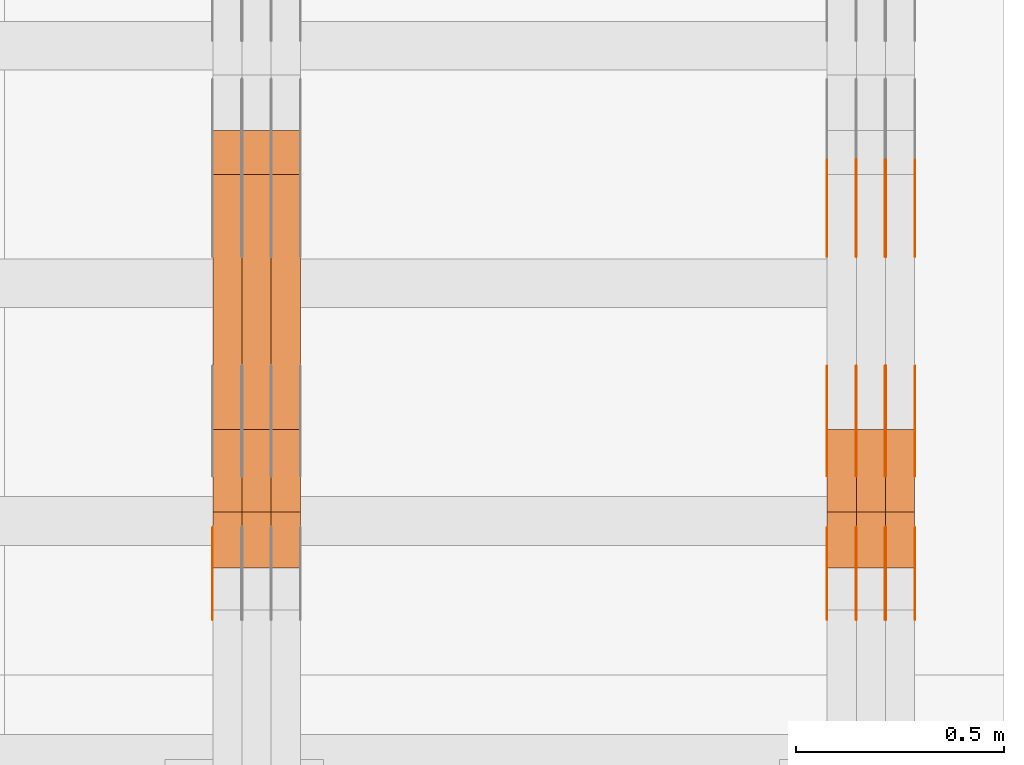
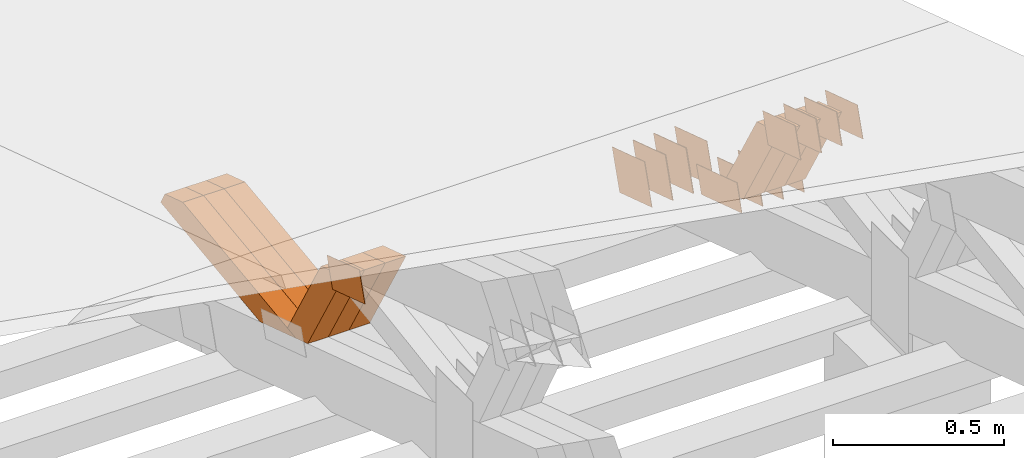
# One storey, part 329 of 385: 28 proxies.
"""IFC2X3 building model written with IfcOpenShell, lengths in millimetres."""

from ifc_helpers import new_model, entity, si_unit, converted_unit, derived_unit, direction, frame, origin, place, context, subcontext, project, spatial, polyline, outline, extrude, source, transform, mapped, material, type_object, type_shapes, element, save


model = new_model("IFC2X3")

# Units and contexts
model_context = context("Model", 3, precision=0.01, world=origin(), true_north=direction((6.12303176911189e-17, 1.0)))
body_context = subcontext(model_context, "Body", "Model", "MODEL_VIEW")
ifc_project = project(units=[si_unit("LENGTHUNIT", "METRE", prefix="MILLI"), si_unit("AREAUNIT", "SQUARE_METRE"), si_unit("VOLUMEUNIT", "CUBIC_METRE"), converted_unit("PLANEANGLEUNIT", "DEGREE", entity("IfcRatioMeasure", 0.0174532925199433), si_unit("PLANEANGLEUNIT", "RADIAN"), dimensions=[0, 0, 0, 0, 0, 0, 0]), si_unit("MASSUNIT", "GRAM", prefix="KILO"), derived_unit("MASSDENSITYUNIT", [(si_unit("MASSUNIT", "GRAM", prefix="KILO"), 1), (si_unit("LENGTHUNIT", "METRE"), -3)]), si_unit("TIMEUNIT", "SECOND"), si_unit("FREQUENCYUNIT", "HERTZ"), si_unit("THERMODYNAMICTEMPERATUREUNIT", "DEGREE_CELSIUS"), derived_unit("THERMALTRANSMITTANCEUNIT", [(si_unit("MASSUNIT", "GRAM", prefix="KILO"), 1), (si_unit("THERMODYNAMICTEMPERATUREUNIT", "KELVIN"), -1), (si_unit("TIMEUNIT", "SECOND"), -3)]), derived_unit("VOLUMETRICFLOWRATEUNIT", [(si_unit("LENGTHUNIT", "METRE"), 3), (si_unit("TIMEUNIT", "SECOND"), -1)]), si_unit("ELECTRICCURRENTUNIT", "AMPERE"), si_unit("ELECTRICVOLTAGEUNIT", "VOLT"), si_unit("POWERUNIT", "WATT"), si_unit("FORCEUNIT", "NEWTON", prefix="KILO"), si_unit("ILLUMINANCEUNIT", "LUX"), si_unit("LUMINOUSFLUXUNIT", "LUMEN"), si_unit("LUMINOUSINTENSITYUNIT", "CANDELA"), derived_unit("USERDEFINED", [(si_unit("MASSUNIT", "GRAM", prefix="KILO"), -1), (si_unit("LENGTHUNIT", "METRE"), -2), (si_unit("TIMEUNIT", "SECOND"), 3), (si_unit("LUMINOUSFLUXUNIT", "LUMEN"), 1)]), derived_unit("LINEARVELOCITYUNIT", [(si_unit("LENGTHUNIT", "METRE"), 1), (si_unit("TIMEUNIT", "SECOND"), -1)]), si_unit("PRESSUREUNIT", "PASCAL"), derived_unit("USERDEFINED", [(si_unit("LENGTHUNIT", "METRE"), -2), (si_unit("MASSUNIT", "GRAM", prefix="KILO"), 1), (si_unit("TIMEUNIT", "SECOND"), -2)])], contexts=[model_context])

# Site, building, storey
site_placement = place(None, origin())
site = spatial("IfcSite", under=ifc_project, at=site_placement, CompositionType="ELEMENT")
building_placement = place(site_placement, origin())
building = spatial("IfcBuilding", under=site, at=building_placement, CompositionType="ELEMENT")
storey_placement = place(building_placement, origin())
storey = spatial("IfcBuildingStorey", under=building, at=storey_placement, Name="Default", CompositionType="ELEMENT", Elevation=0.0)

# Proxies
ifc_material_1 = material(Name="IfcSurfaceStyle #617878")
building_element_proxy_type_1 = type_object("IfcBuildingElementProxyType", PredefinedType="NOTDEFINED", material=ifc_material_1)
shared_shape_1 = source(origin(), body_context, "Body", "SweptSolid", [
    extrude(outline(polyline([(-125.00031378339, -47.9999612158856), (125.000225258022, -47.9999612158856), (124.999811678525, 47.9999612158856), (-124.999723153156, 47.9999612158856), (-125.00031378339, -47.9999612158856)])), frame((125.000225258022, 48.0000091013474, 0.0), z_axis=(0.0, 0.0, 1.0), x_axis=(-1.0, 0.0, 0.0)), (0.0, 0.0, 1.0), 1.3),
])
type_shapes(building_element_proxy_type_1, [shared_shape_1])
proxy_1_placement = place(building_placement, frame((49861.3, 18456.8597683375, 2657.46691321253), z_axis=(-1.0, 0.0, 0.0), x_axis=(0.0, -0.951056516295124, 0.309016994375039)))
element("IfcBuildingElementProxy", 1, at=proxy_1_placement, inside=storey, type_object=building_element_proxy_type_1, material=ifc_material_1, context=body_context, shape_type="MappedRepresentation", body=[
    mapped(shared_shape_1, transform((0.0, 0.0, 0.0), scale=1.0)),
])
ifc_material_2 = material(Name="IfcSurfaceStyle #617821")
building_element_proxy_type_2 = type_object("IfcBuildingElementProxyType", PredefinedType="NOTDEFINED", material=ifc_material_2)
shared_shape_2 = source(origin(), body_context, "Body", "SweptSolid", [
    extrude(outline(polyline([(-125.00031378339, -47.9999612158856), (125.000225258022, -47.9999612158856), (124.999811678525, 47.9999612158856), (-124.999723153156, 47.9999612158856), (-125.00031378339, -47.9999612158856)])), frame((125.000225258022, 48.0000091013474, 0.0), z_axis=(0.0, 0.0, 1.0), x_axis=(-1.0, 0.0, 0.0)), (0.0, 0.0, 1.0), 1.3),
])
type_shapes(building_element_proxy_type_2, [shared_shape_2])
proxy_2_placement = place(building_placement, frame((49790.0, 18456.8597683375, 2657.46691321253), z_axis=(-1.0, 0.0, 0.0), x_axis=(0.0, -0.951056516295124, 0.309016994375039)))
element("IfcBuildingElementProxy", 2, at=proxy_2_placement, inside=storey, type_object=building_element_proxy_type_2, material=ifc_material_2, context=body_context, shape_type="MappedRepresentation", body=[
    mapped(shared_shape_2, transform((0.0, 0.0, 0.0), scale=1.0)),
])
ifc_material_3 = material(Name="IfcSurfaceStyle #617764")
building_element_proxy_type_3 = type_object("IfcBuildingElementProxyType", PredefinedType="NOTDEFINED", material=ifc_material_3)
shared_shape_3 = source(origin(), body_context, "Body", "SweptSolid", [
    extrude(outline(polyline([(-125.00031378339, -47.9999612158856), (125.000225258022, -47.9999612158856), (124.999811678525, 47.9999612158856), (-124.999723153156, 47.9999612158856), (-125.00031378339, -47.9999612158856)])), frame((125.000225258022, 48.0000091013474, 0.0), z_axis=(0.0, 0.0, 1.0), x_axis=(-1.0, 0.0, 0.0)), (0.0, 0.0, 1.0), 1.3),
])
type_shapes(building_element_proxy_type_3, [shared_shape_3])
proxy_3_placement = place(building_placement, frame((49791.3, 18456.8597683375, 2657.46691321253), z_axis=(-1.0, 0.0, 0.0), x_axis=(0.0, -0.951056516295124, 0.309016994375039)))
element("IfcBuildingElementProxy", 3, at=proxy_3_placement, inside=storey, type_object=building_element_proxy_type_3, material=ifc_material_3, context=body_context, shape_type="MappedRepresentation", body=[
    mapped(shared_shape_3, transform((0.0, 0.0, 0.0), scale=1.0)),
])
ifc_material_4 = material(Name="IfcSurfaceStyle #617707")
building_element_proxy_type_4 = type_object("IfcBuildingElementProxyType", PredefinedType="NOTDEFINED", material=ifc_material_4)
shared_shape_4 = source(origin(), body_context, "Body", "SweptSolid", [
    extrude(outline(polyline([(-125.00031378339, -47.9999612158856), (125.000225258022, -47.9999612158856), (124.999811678525, 47.9999612158856), (-124.999723153156, 47.9999612158856), (-125.00031378339, -47.9999612158856)])), frame((125.000225258022, 48.0000091013474, 0.0), z_axis=(0.0, 0.0, 1.0), x_axis=(-1.0, 0.0, 0.0)), (0.0, 0.0, 1.0), 1.29999999999998),
])
type_shapes(building_element_proxy_type_4, [shared_shape_4])
proxy_4_placement = place(building_placement, frame((49720.0, 18456.8597683375, 2657.46691321253), z_axis=(-1.0, 0.0, 0.0), x_axis=(0.0, -0.951056516295124, 0.309016994375039)))
element("IfcBuildingElementProxy", 4, at=proxy_4_placement, inside=storey, type_object=building_element_proxy_type_4, material=ifc_material_4, context=body_context, shape_type="MappedRepresentation", body=[
    mapped(shared_shape_4, transform((0.0, 0.0, 0.0), scale=1.0)),
])
ifc_material_5 = material(Name="IfcSurfaceStyle #617650")
building_element_proxy_type_5 = type_object("IfcBuildingElementProxyType", PredefinedType="NOTDEFINED", material=ifc_material_5)
shared_shape_5 = source(origin(), body_context, "Body", "SweptSolid", [
    extrude(outline(polyline([(-125.00031378339, -47.9999612158856), (125.000225258022, -47.9999612158856), (124.999811678525, 47.9999612158856), (-124.999723153156, 47.9999612158856), (-125.00031378339, -47.9999612158856)])), frame((125.000225258022, 48.0000091013474, 0.0), z_axis=(0.0, 0.0, 1.0), x_axis=(-1.0, 0.0, 0.0)), (0.0, 0.0, 1.0), 1.29999999999998),
])
type_shapes(building_element_proxy_type_5, [shared_shape_5])
proxy_5_placement = place(building_placement, frame((49721.3, 18456.8597683375, 2657.46691321253), z_axis=(-1.0, 0.0, 0.0), x_axis=(0.0, -0.951056516295124, 0.309016994375039)))
element("IfcBuildingElementProxy", 5, at=proxy_5_placement, inside=storey, type_object=building_element_proxy_type_5, material=ifc_material_5, context=body_context, shape_type="MappedRepresentation", body=[
    mapped(shared_shape_5, transform((0.0, 0.0, 0.0), scale=1.0)),
])
ifc_material_6 = material(Name="IfcSurfaceStyle #617593")
building_element_proxy_type_6 = type_object("IfcBuildingElementProxyType", PredefinedType="NOTDEFINED", material=ifc_material_6)
shared_shape_6 = source(origin(), body_context, "Body", "SweptSolid", [
    extrude(outline(polyline([(-125.00031378339, -47.9999612158856), (125.000225258022, -47.9999612158856), (124.999811678525, 47.9999612158856), (-124.999723153156, 47.9999612158856), (-125.00031378339, -47.9999612158856)])), frame((125.000225258022, 48.0000091013474, 0.0), z_axis=(0.0, 0.0, 1.0), x_axis=(-1.0, 0.0, 0.0)), (0.0, 0.0, 1.0), 1.29999999999998),
])
type_shapes(building_element_proxy_type_6, [shared_shape_6])
proxy_6_placement = place(building_placement, frame((49650.0, 18456.8597683375, 2657.46691321253), z_axis=(-1.0, 0.0, 0.0), x_axis=(0.0, -0.951056516295124, 0.309016994375039)))
element("IfcBuildingElementProxy", 6, at=proxy_6_placement, inside=storey, type_object=building_element_proxy_type_6, material=ifc_material_6, context=body_context, shape_type="MappedRepresentation", body=[
    mapped(shared_shape_6, transform((0.0, 0.0, 0.0), scale=1.0)),
])
ifc_material_7 = material(Name="IfcSurfaceStyle #616168")
building_element_proxy_type_7 = type_object("IfcBuildingElementProxyType", PredefinedType="NOTDEFINED", material=ifc_material_7)
shared_shape_7 = source(origin(), body_context, "Body", "SweptSolid", [
    extrude(outline(polyline([(-99.999796294464, -72.0000050220467), (99.9998768370438, -72.0000050220467), (100.000260677528, 72.0000050220467), (-100.000341220108, 72.0000050220467), (-99.999796294464, -72.0000050220467)])), frame((100.000260677528, 72.0000050220467, 0.0), z_axis=(0.0, 0.0, 1.0), x_axis=(-1.0, 0.0, 0.0)), (0.0, 0.0, 1.0), 1.3),
])
type_shapes(building_element_proxy_type_7, [shared_shape_7])
proxy_7_placement = place(building_placement, frame((49861.3, 18936.3876569477, 2373.90613192527), z_axis=(-1.0, 0.0, 0.0), x_axis=(0.0, -0.951056516295124, 0.309016994375039)))
element("IfcBuildingElementProxy", 7, at=proxy_7_placement, inside=storey, type_object=building_element_proxy_type_7, material=ifc_material_7, context=body_context, shape_type="MappedRepresentation", body=[
    mapped(shared_shape_7, transform((0.0, 0.0, 0.0), scale=1.0)),
])
ifc_material_8 = material(Name="IfcSurfaceStyle #616111")
building_element_proxy_type_8 = type_object("IfcBuildingElementProxyType", PredefinedType="NOTDEFINED", material=ifc_material_8)
shared_shape_8 = source(origin(), body_context, "Body", "SweptSolid", [
    extrude(outline(polyline([(-99.999796294464, -72.0000050220467), (99.9998768370438, -72.0000050220467), (100.000260677528, 72.0000050220467), (-100.000341220108, 72.0000050220467), (-99.999796294464, -72.0000050220467)])), frame((100.000260677528, 72.0000050220467, 0.0), z_axis=(0.0, 0.0, 1.0), x_axis=(-1.0, 0.0, 0.0)), (0.0, 0.0, 1.0), 1.3),
])
type_shapes(building_element_proxy_type_8, [shared_shape_8])
proxy_8_placement = place(building_placement, frame((49790.0, 18936.3876569477, 2373.90613192527), z_axis=(-1.0, 0.0, 0.0), x_axis=(0.0, -0.951056516295124, 0.309016994375039)))
element("IfcBuildingElementProxy", 8, at=proxy_8_placement, inside=storey, type_object=building_element_proxy_type_8, material=ifc_material_8, context=body_context, shape_type="MappedRepresentation", body=[
    mapped(shared_shape_8, transform((0.0, 0.0, 0.0), scale=1.0)),
])
ifc_material_9 = material(Name="IfcSurfaceStyle #616054")
building_element_proxy_type_9 = type_object("IfcBuildingElementProxyType", PredefinedType="NOTDEFINED", material=ifc_material_9)
shared_shape_9 = source(origin(), body_context, "Body", "SweptSolid", [
    extrude(outline(polyline([(-99.999796294464, -72.0000050220467), (99.9998768370438, -72.0000050220467), (100.000260677528, 72.0000050220467), (-100.000341220108, 72.0000050220467), (-99.999796294464, -72.0000050220467)])), frame((100.000260677528, 72.0000050220467, 0.0), z_axis=(0.0, 0.0, 1.0), x_axis=(-1.0, 0.0, 0.0)), (0.0, 0.0, 1.0), 1.3),
])
type_shapes(building_element_proxy_type_9, [shared_shape_9])
proxy_9_placement = place(building_placement, frame((49791.3, 18936.3876569477, 2373.90613192527), z_axis=(-1.0, 0.0, 0.0), x_axis=(0.0, -0.951056516295124, 0.309016994375039)))
element("IfcBuildingElementProxy", 9, at=proxy_9_placement, inside=storey, type_object=building_element_proxy_type_9, material=ifc_material_9, context=body_context, shape_type="MappedRepresentation", body=[
    mapped(shared_shape_9, transform((0.0, 0.0, 0.0), scale=1.0)),
])
ifc_material_10 = material(Name="IfcSurfaceStyle #615997")
building_element_proxy_type_10 = type_object("IfcBuildingElementProxyType", PredefinedType="NOTDEFINED", material=ifc_material_10)
shared_shape_10 = source(origin(), body_context, "Body", "SweptSolid", [
    extrude(outline(polyline([(-99.999796294464, -72.0000050220467), (99.9998768370438, -72.0000050220467), (100.000260677528, 72.0000050220467), (-100.000341220108, 72.0000050220467), (-99.999796294464, -72.0000050220467)])), frame((100.000260677528, 72.0000050220467, 0.0), z_axis=(0.0, 0.0, 1.0), x_axis=(-1.0, 0.0, 0.0)), (0.0, 0.0, 1.0), 1.29999999999998),
])
type_shapes(building_element_proxy_type_10, [shared_shape_10])
proxy_10_placement = place(building_placement, frame((49720.0, 18936.3876569477, 2373.90613192527), z_axis=(-1.0, 0.0, 0.0), x_axis=(0.0, -0.951056516295124, 0.309016994375039)))
element("IfcBuildingElementProxy", 10, at=proxy_10_placement, inside=storey, type_object=building_element_proxy_type_10, material=ifc_material_10, context=body_context, shape_type="MappedRepresentation", body=[
    mapped(shared_shape_10, transform((0.0, 0.0, 0.0), scale=1.0)),
])
ifc_material_11 = material(Name="IfcSurfaceStyle #615940")
building_element_proxy_type_11 = type_object("IfcBuildingElementProxyType", PredefinedType="NOTDEFINED", material=ifc_material_11)
shared_shape_11 = source(origin(), body_context, "Body", "SweptSolid", [
    extrude(outline(polyline([(-99.999796294464, -72.0000050220467), (99.9998768370438, -72.0000050220467), (100.000260677528, 72.0000050220467), (-100.000341220108, 72.0000050220467), (-99.999796294464, -72.0000050220467)])), frame((100.000260677528, 72.0000050220467, 0.0), z_axis=(0.0, 0.0, 1.0), x_axis=(-1.0, 0.0, 0.0)), (0.0, 0.0, 1.0), 1.29999999999998),
])
type_shapes(building_element_proxy_type_11, [shared_shape_11])
proxy_11_placement = place(building_placement, frame((49721.3, 18936.3876569477, 2373.90613192527), z_axis=(-1.0, 0.0, 0.0), x_axis=(0.0, -0.951056516295124, 0.309016994375039)))
element("IfcBuildingElementProxy", 11, at=proxy_11_placement, inside=storey, type_object=building_element_proxy_type_11, material=ifc_material_11, context=body_context, shape_type="MappedRepresentation", body=[
    mapped(shared_shape_11, transform((0.0, 0.0, 0.0), scale=1.0)),
])
ifc_material_12 = material(Name="IfcSurfaceStyle #615883")
building_element_proxy_type_12 = type_object("IfcBuildingElementProxyType", PredefinedType="NOTDEFINED", material=ifc_material_12)
shared_shape_12 = source(origin(), body_context, "Body", "SweptSolid", [
    extrude(outline(polyline([(-99.999796294464, -72.0000050220467), (99.9998768370438, -72.0000050220467), (100.000260677528, 72.0000050220467), (-100.000341220108, 72.0000050220467), (-99.999796294464, -72.0000050220467)])), frame((100.000260677528, 72.0000050220467, 0.0), z_axis=(0.0, 0.0, 1.0), x_axis=(-1.0, 0.0, 0.0)), (0.0, 0.0, 1.0), 1.29999999999999),
])
type_shapes(building_element_proxy_type_12, [shared_shape_12])
proxy_12_placement = place(building_placement, frame((49650.0, 18936.3876569477, 2373.90613192527), z_axis=(-1.0, 0.0, 0.0), x_axis=(0.0, -0.951056516295124, 0.309016994375039)))
element("IfcBuildingElementProxy", 12, at=proxy_12_placement, inside=storey, type_object=building_element_proxy_type_12, material=ifc_material_12, context=body_context, shape_type="MappedRepresentation", body=[
    mapped(shared_shape_12, transform((0.0, 0.0, 0.0), scale=1.0)),
])
ifc_material_13 = material(Name="IfcSurfaceStyle #611722")
building_element_proxy_type_13 = type_object("IfcBuildingElementProxyType", PredefinedType="NOTDEFINED", material=ifc_material_13)
shared_shape_13 = source(origin(), body_context, "Body", "SweptSolid", [
    extrude(outline(polyline([(-99.9999427841299, -54.0000599375792), (99.9996549037756, -54.0000599375792), (100.000407167194, 54.0000599375792), (-100.00011928684, 54.0000599375792), (-99.9999427841299, -54.0000599375792)])), frame((100.000407167194, 54.0000599375792, 0.0), z_axis=(0.0, 0.0, 1.0), x_axis=(-1.0, 0.0, 0.0)), (0.0, 0.0, 1.0), 1.3),
])
type_shapes(building_element_proxy_type_13, [shared_shape_13])
proxy_13_placement = place(building_placement, frame((49861.3, 18065.0682492591, 3072.55239547302), z_axis=(-1.0, 0.0, 0.0), x_axis=(0.0, -0.951056516295154, 0.309016994374948)))
element("IfcBuildingElementProxy", 13, at=proxy_13_placement, inside=storey, type_object=building_element_proxy_type_13, material=ifc_material_13, context=body_context, shape_type="MappedRepresentation", body=[
    mapped(shared_shape_13, transform((0.0, 0.0, 0.0), scale=1.0)),
])
ifc_material_14 = material(Name="IfcSurfaceStyle #611665")
building_element_proxy_type_14 = type_object("IfcBuildingElementProxyType", PredefinedType="NOTDEFINED", material=ifc_material_14)
shared_shape_14 = source(origin(), body_context, "Body", "SweptSolid", [
    extrude(outline(polyline([(-99.9999427841299, -54.0000599375792), (99.9996549037756, -54.0000599375792), (100.000407167194, 54.0000599375792), (-100.00011928684, 54.0000599375792), (-99.9999427841299, -54.0000599375792)])), frame((100.000407167194, 54.0000599375792, 0.0), z_axis=(0.0, 0.0, 1.0), x_axis=(-1.0, 0.0, 0.0)), (0.0, 0.0, 1.0), 1.3),
])
type_shapes(building_element_proxy_type_14, [shared_shape_14])
proxy_14_placement = place(building_placement, frame((49790.0, 18065.0682492591, 3072.55239547302), z_axis=(-1.0, 0.0, 0.0), x_axis=(0.0, -0.951056516295154, 0.309016994374948)))
element("IfcBuildingElementProxy", 14, at=proxy_14_placement, inside=storey, type_object=building_element_proxy_type_14, material=ifc_material_14, context=body_context, shape_type="MappedRepresentation", body=[
    mapped(shared_shape_14, transform((0.0, 0.0, 0.0), scale=1.0)),
])
ifc_material_15 = material(Name="IfcSurfaceStyle #611608")
building_element_proxy_type_15 = type_object("IfcBuildingElementProxyType", PredefinedType="NOTDEFINED", material=ifc_material_15)
shared_shape_15 = source(origin(), body_context, "Body", "SweptSolid", [
    extrude(outline(polyline([(-99.9999427841299, -54.0000599375792), (99.9996549037756, -54.0000599375792), (100.000407167194, 54.0000599375792), (-100.00011928684, 54.0000599375792), (-99.9999427841299, -54.0000599375792)])), frame((100.000407167194, 54.0000599375792, 0.0), z_axis=(0.0, 0.0, 1.0), x_axis=(-1.0, 0.0, 0.0)), (0.0, 0.0, 1.0), 1.3),
])
type_shapes(building_element_proxy_type_15, [shared_shape_15])
proxy_15_placement = place(building_placement, frame((49791.3, 18065.0682492591, 3072.55239547302), z_axis=(-1.0, 0.0, 0.0), x_axis=(0.0, -0.951056516295154, 0.309016994374948)))
element("IfcBuildingElementProxy", 15, at=proxy_15_placement, inside=storey, type_object=building_element_proxy_type_15, material=ifc_material_15, context=body_context, shape_type="MappedRepresentation", body=[
    mapped(shared_shape_15, transform((0.0, 0.0, 0.0), scale=1.0)),
])
ifc_material_16 = material(Name="IfcSurfaceStyle #611551")
building_element_proxy_type_16 = type_object("IfcBuildingElementProxyType", PredefinedType="NOTDEFINED", material=ifc_material_16)
shared_shape_16 = source(origin(), body_context, "Body", "SweptSolid", [
    extrude(outline(polyline([(-99.9999427841299, -54.0000599375792), (99.9996549037756, -54.0000599375792), (100.000407167194, 54.0000599375792), (-100.00011928684, 54.0000599375792), (-99.9999427841299, -54.0000599375792)])), frame((100.000407167194, 54.0000599375792, 0.0), z_axis=(0.0, 0.0, 1.0), x_axis=(-1.0, 0.0, 0.0)), (0.0, 0.0, 1.0), 1.29999999999998),
])
type_shapes(building_element_proxy_type_16, [shared_shape_16])
proxy_16_placement = place(building_placement, frame((49720.0, 18065.0682492591, 3072.55239547302), z_axis=(-1.0, 0.0, 0.0), x_axis=(0.0, -0.951056516295154, 0.309016994374948)))
element("IfcBuildingElementProxy", 16, at=proxy_16_placement, inside=storey, type_object=building_element_proxy_type_16, material=ifc_material_16, context=body_context, shape_type="MappedRepresentation", body=[
    mapped(shared_shape_16, transform((0.0, 0.0, 0.0), scale=1.0)),
])
ifc_material_17 = material(Name="IfcSurfaceStyle #611494")
building_element_proxy_type_17 = type_object("IfcBuildingElementProxyType", PredefinedType="NOTDEFINED", material=ifc_material_17)
shared_shape_17 = source(origin(), body_context, "Body", "SweptSolid", [
    extrude(outline(polyline([(-99.9999427841299, -54.0000599375792), (99.9996549037756, -54.0000599375792), (100.000407167194, 54.0000599375792), (-100.00011928684, 54.0000599375792), (-99.9999427841299, -54.0000599375792)])), frame((100.000407167194, 54.0000599375792, 0.0), z_axis=(0.0, 0.0, 1.0), x_axis=(-1.0, 0.0, 0.0)), (0.0, 0.0, 1.0), 1.29999999999998),
])
type_shapes(building_element_proxy_type_17, [shared_shape_17])
proxy_17_placement = place(building_placement, frame((49721.3, 18065.0682492591, 3072.55239547302), z_axis=(-1.0, 0.0, 0.0), x_axis=(0.0, -0.951056516295154, 0.309016994374948)))
element("IfcBuildingElementProxy", 17, at=proxy_17_placement, inside=storey, type_object=building_element_proxy_type_17, material=ifc_material_17, context=body_context, shape_type="MappedRepresentation", body=[
    mapped(shared_shape_17, transform((0.0, 0.0, 0.0), scale=1.0)),
])
ifc_material_18 = material(Name="IfcSurfaceStyle #611437")
building_element_proxy_type_18 = type_object("IfcBuildingElementProxyType", PredefinedType="NOTDEFINED", material=ifc_material_18)
shared_shape_18 = source(origin(), body_context, "Body", "SweptSolid", [
    extrude(outline(polyline([(-99.9999427841299, -54.0000599375792), (99.9996549037756, -54.0000599375792), (100.000407167194, 54.0000599375792), (-100.00011928684, 54.0000599375792), (-99.9999427841299, -54.0000599375792)])), frame((100.000407167194, 54.0000599375792, 0.0), z_axis=(0.0, 0.0, 1.0), x_axis=(-1.0, 0.0, 0.0)), (0.0, 0.0, 1.0), 1.29999999999999),
])
type_shapes(building_element_proxy_type_18, [shared_shape_18])
proxy_18_placement = place(building_placement, frame((49650.0, 18065.0682492591, 3072.55239547302), z_axis=(-1.0, 0.0, 0.0), x_axis=(0.0, -0.951056516295154, 0.309016994374948)))
element("IfcBuildingElementProxy", 18, at=proxy_18_placement, inside=storey, type_object=building_element_proxy_type_18, material=ifc_material_18, context=body_context, shape_type="MappedRepresentation", body=[
    mapped(shared_shape_18, transform((0.0, 0.0, 0.0), scale=1.0)),
])
ifc_material_19 = material(Name="IfcSurfaceStyle #601570")
building_element_proxy_type_19 = type_object("IfcBuildingElementProxyType", Name="T2-W35 601568", PredefinedType="NOTDEFINED", material=ifc_material_19)
shared_shape_19 = source(origin(), body_context, "Body", "SweptSolid", [
    extrude(outline(polyline([(-196.877231354918, -47.499850828051), (197.289756738813, -47.499850828051), (177.380838136073, -0.000131002767018074), (124.615181369032, 47.4999163294346), (-302.408544889, 47.4999163294346), (-196.877231354918, -47.499850828051)])), frame((197.289756738813, 47.5002438363521, 0.0), z_axis=(0.0, 0.0, 1.0), x_axis=(-1.0, 0.0, 0.0)), (0.0, 0.0, 1.0), 70.0),
])
type_shapes(building_element_proxy_type_19, [shared_shape_19])
proxy_19_placement = place(building_placement, frame((49860.0, 18249.5528960018, 2724.16980022534), z_axis=(-1.0, 0.0, 0.0), x_axis=(0.0, -0.5, 0.866025403784439)))
element("IfcBuildingElementProxy", 19, at=proxy_19_placement, inside=storey, type_object=building_element_proxy_type_19, material=ifc_material_19, Name="T2-W35", context=body_context, shape_type="MappedRepresentation", body=[
    mapped(shared_shape_19, transform((0.0, 0.0, 0.0), scale=1.0)),
])
ifc_material_20 = material(Name="IfcSurfaceStyle #601504")
building_element_proxy_type_20 = type_object("IfcBuildingElementProxyType", Name="T2-W35 601502", PredefinedType="NOTDEFINED", material=ifc_material_20)
shared_shape_20 = source(origin(), body_context, "Body", "SweptSolid", [
    extrude(outline(polyline([(-196.877231354918, -47.499850828051), (197.289756738813, -47.499850828051), (177.380838136073, -0.000131002767018074), (124.615181369032, 47.4999163294346), (-302.408544889, 47.4999163294346), (-196.877231354918, -47.499850828051)])), frame((197.289756738813, 47.5002438363521, 0.0), z_axis=(0.0, 0.0, 1.0), x_axis=(-1.0, 0.0, 0.0)), (0.0, 0.0, 1.0), 70.0),
])
type_shapes(building_element_proxy_type_20, [shared_shape_20])
proxy_20_placement = place(building_placement, frame((49790.0, 18249.5528960018, 2724.16980022534), z_axis=(-1.0, 0.0, 0.0), x_axis=(0.0, -0.5, 0.866025403784439)))
element("IfcBuildingElementProxy", 20, at=proxy_20_placement, inside=storey, type_object=building_element_proxy_type_20, material=ifc_material_20, Name="T2-W35", context=body_context, shape_type="MappedRepresentation", body=[
    mapped(shared_shape_20, transform((0.0, 0.0, 0.0), scale=1.0)),
])
ifc_material_21 = material(Name="IfcSurfaceStyle #601438")
building_element_proxy_type_21 = type_object("IfcBuildingElementProxyType", Name="T2-W35 601436", PredefinedType="NOTDEFINED", material=ifc_material_21)
shared_shape_21 = source(origin(), body_context, "Body", "SweptSolid", [
    extrude(outline(polyline([(-196.877231354918, -47.499850828051), (197.289756738813, -47.499850828051), (177.380838136073, -0.000131002767018074), (124.615181369032, 47.4999163294346), (-302.408544889, 47.4999163294346), (-196.877231354918, -47.499850828051)])), frame((197.289756738813, 47.5002438363521, 0.0), z_axis=(0.0, 0.0, 1.0), x_axis=(-1.0, 0.0, 0.0)), (0.0, 0.0, 1.0), 70.0),
])
type_shapes(building_element_proxy_type_21, [shared_shape_21])
proxy_21_placement = place(building_placement, frame((49720.0, 18249.5528960018, 2724.16980022534), z_axis=(-1.0, 0.0, 0.0), x_axis=(0.0, -0.5, 0.866025403784439)))
element("IfcBuildingElementProxy", 21, at=proxy_21_placement, inside=storey, type_object=building_element_proxy_type_21, material=ifc_material_21, Name="T2-W35", context=body_context, shape_type="MappedRepresentation", body=[
    mapped(shared_shape_21, transform((0.0, 0.0, 0.0), scale=1.0)),
])
ifc_material_22 = material(Name="IfcSurfaceStyle #577005")
building_element_proxy_type_22 = type_object("IfcBuildingElementProxyType", PredefinedType="NOTDEFINED", material=ifc_material_22)
shared_shape_22 = source(origin(), body_context, "Body", "SweptSolid", [
    extrude(outline(polyline([(-99.9999427841299, -54.0000599375792), (99.9996549037756, -54.0000599375792), (100.000407167194, 54.0000599375792), (-100.00011928684, 54.0000599375792), (-99.9999427841299, -54.0000599375792)])), frame((100.000407167194, 54.0000599375792, 0.0), z_axis=(0.0, 0.0, 1.0), x_axis=(-1.0, 0.0, 0.0)), (0.0, 0.0, 1.0), 1.29999999999999),
])
type_shapes(building_element_proxy_type_22, [shared_shape_22])
proxy_22_placement = place(building_placement, frame((48175.0, 18065.0682492591, 3072.55239547302), z_axis=(-1.0, 0.0, 0.0), x_axis=(0.0, -0.951056516295154, 0.309016994374948)))
element("IfcBuildingElementProxy", 22, at=proxy_22_placement, inside=storey, type_object=building_element_proxy_type_22, material=ifc_material_22, context=body_context, shape_type="MappedRepresentation", body=[
    mapped(shared_shape_22, transform((0.0, 0.0, 0.0), scale=1.0)),
])
ifc_material_23 = material(Name="IfcSurfaceStyle #567138")
building_element_proxy_type_23 = type_object("IfcBuildingElementProxyType", Name="T1-W35 567136", PredefinedType="NOTDEFINED", material=ifc_material_23)
shared_shape_23 = source(origin(), body_context, "Body", "SweptSolid", [
    extrude(outline(polyline([(-196.877231354918, -47.499850828051), (197.289756738813, -47.499850828051), (177.380838136073, -0.000131002767018074), (124.615181369032, 47.4999163294346), (-302.408544889, 47.4999163294346), (-196.877231354918, -47.499850828051)])), frame((197.289756738813, 47.5002438363521, 0.0), z_axis=(0.0, 0.0, 1.0), x_axis=(-1.0, 0.0, 0.0)), (0.0, 0.0, 1.0), 70.0),
])
type_shapes(building_element_proxy_type_23, [shared_shape_23])
proxy_23_placement = place(building_placement, frame((48385.0, 18249.5528960018, 2724.16980022534), z_axis=(-1.0, 0.0, 0.0), x_axis=(0.0, -0.5, 0.866025403784439)))
element("IfcBuildingElementProxy", 23, at=proxy_23_placement, inside=storey, type_object=building_element_proxy_type_23, material=ifc_material_23, Name="T1-W35", context=body_context, shape_type="MappedRepresentation", body=[
    mapped(shared_shape_23, transform((0.0, 0.0, 0.0), scale=1.0)),
])
ifc_material_24 = material(Name="IfcSurfaceStyle #567072")
building_element_proxy_type_24 = type_object("IfcBuildingElementProxyType", Name="T1-W35 567070", PredefinedType="NOTDEFINED", material=ifc_material_24)
shared_shape_24 = source(origin(), body_context, "Body", "SweptSolid", [
    extrude(outline(polyline([(-196.877231354918, -47.499850828051), (197.289756738813, -47.499850828051), (177.380838136073, -0.000131002767018074), (124.615181369032, 47.4999163294346), (-302.408544889, 47.4999163294346), (-196.877231354918, -47.499850828051)])), frame((197.289756738813, 47.5002438363521, 0.0), z_axis=(0.0, 0.0, 1.0), x_axis=(-1.0, 0.0, 0.0)), (0.0, 0.0, 1.0), 70.0),
])
type_shapes(building_element_proxy_type_24, [shared_shape_24])
proxy_24_placement = place(building_placement, frame((48315.0, 18249.5528960018, 2724.16980022534), z_axis=(-1.0, 0.0, 0.0), x_axis=(0.0, -0.5, 0.866025403784439)))
element("IfcBuildingElementProxy", 24, at=proxy_24_placement, inside=storey, type_object=building_element_proxy_type_24, material=ifc_material_24, Name="T1-W35", context=body_context, shape_type="MappedRepresentation", body=[
    mapped(shared_shape_24, transform((0.0, 0.0, 0.0), scale=1.0)),
])
ifc_material_25 = material(Name="IfcSurfaceStyle #567006")
building_element_proxy_type_25 = type_object("IfcBuildingElementProxyType", Name="T1-W35 567004", PredefinedType="NOTDEFINED", material=ifc_material_25)
shared_shape_25 = source(origin(), body_context, "Body", "SweptSolid", [
    extrude(outline(polyline([(-196.877231354918, -47.499850828051), (197.289756738813, -47.499850828051), (177.380838136073, -0.000131002767018074), (124.615181369032, 47.4999163294346), (-302.408544889, 47.4999163294346), (-196.877231354918, -47.499850828051)])), frame((197.289756738813, 47.5002438363521, 0.0), z_axis=(0.0, 0.0, 1.0), x_axis=(-1.0, 0.0, 0.0)), (0.0, 0.0, 1.0), 70.0),
])
type_shapes(building_element_proxy_type_25, [shared_shape_25])
proxy_25_placement = place(building_placement, frame((48245.0, 18249.5528960018, 2724.16980022534), z_axis=(-1.0, 0.0, 0.0), x_axis=(0.0, -0.5, 0.866025403784439)))
element("IfcBuildingElementProxy", 25, at=proxy_25_placement, inside=storey, type_object=building_element_proxy_type_25, material=ifc_material_25, Name="T1-W35", context=body_context, shape_type="MappedRepresentation", body=[
    mapped(shared_shape_25, transform((0.0, 0.0, 0.0), scale=1.0)),
])
ifc_material_26 = material(Name="IfcSurfaceStyle #566742")
building_element_proxy_type_26 = type_object("IfcBuildingElementProxyType", Name="T1-W6 566740", PredefinedType="NOTDEFINED", material=ifc_material_26)
shared_shape_26 = source(origin(), body_context, "Body", "SweptSolid", [
    extrude(outline(polyline([(-485.945461934772, -47.500204767976), (183.41906495488, -47.500204767976), (284.061400026172, 0.000179660053988773), (303.127757064591, 47.500114937949), (-284.66276011087, 47.500114937949), (-485.945461934772, -47.500204767976)])), frame((303.127970456024, 47.5001450766485, 0.0), z_axis=(0.0, 0.0, 1.0), x_axis=(-1.0, 0.0, 0.0)), (0.0, 0.0, 1.0), 70.0),
])
type_shapes(building_element_proxy_type_26, [shared_shape_26])
proxy_26_placement = place(building_placement, frame((48385.0, 19075.4826373647, 2770.72729201433), z_axis=(-1.0, 0.0, 0.0), x_axis=(0.0, -0.991969529622927, -0.126477082112413)))
element("IfcBuildingElementProxy", 26, at=proxy_26_placement, inside=storey, type_object=building_element_proxy_type_26, material=ifc_material_26, Name="T1-W6", context=body_context, shape_type="MappedRepresentation", body=[
    mapped(shared_shape_26, transform((0.0, 0.0, 0.0), scale=1.0)),
])
ifc_material_27 = material(Name="IfcSurfaceStyle #566676")
building_element_proxy_type_27 = type_object("IfcBuildingElementProxyType", Name="T1-W6 566674", PredefinedType="NOTDEFINED", material=ifc_material_27)
shared_shape_27 = source(origin(), body_context, "Body", "SweptSolid", [
    extrude(outline(polyline([(-485.945461934772, -47.500204767976), (183.41906495488, -47.500204767976), (284.061400026172, 0.000179660053988773), (303.127757064591, 47.500114937949), (-284.66276011087, 47.500114937949), (-485.945461934772, -47.500204767976)])), frame((303.127970456024, 47.5001450766485, 0.0), z_axis=(0.0, 0.0, 1.0), x_axis=(-1.0, 0.0, 0.0)), (0.0, 0.0, 1.0), 70.0),
])
type_shapes(building_element_proxy_type_27, [shared_shape_27])
proxy_27_placement = place(building_placement, frame((48315.0, 19075.4826373647, 2770.72729201433), z_axis=(-1.0, 0.0, 0.0), x_axis=(0.0, -0.991969529622927, -0.126477082112413)))
element("IfcBuildingElementProxy", 27, at=proxy_27_placement, inside=storey, type_object=building_element_proxy_type_27, material=ifc_material_27, Name="T1-W6", context=body_context, shape_type="MappedRepresentation", body=[
    mapped(shared_shape_27, transform((0.0, 0.0, 0.0), scale=1.0)),
])
ifc_material_28 = material(Name="IfcSurfaceStyle #566610")
building_element_proxy_type_28 = type_object("IfcBuildingElementProxyType", Name="T1-W6 566608", PredefinedType="NOTDEFINED", material=ifc_material_28)
shared_shape_28 = source(origin(), body_context, "Body", "SweptSolid", [
    extrude(outline(polyline([(-485.945461934772, -47.500204767976), (183.41906495488, -47.500204767976), (284.061400026172, 0.000179660053988773), (303.127757064591, 47.500114937949), (-284.66276011087, 47.500114937949), (-485.945461934772, -47.500204767976)])), frame((303.127970456024, 47.5001450766485, 0.0), z_axis=(0.0, 0.0, 1.0), x_axis=(-1.0, 0.0, 0.0)), (0.0, 0.0, 1.0), 70.0),
])
type_shapes(building_element_proxy_type_28, [shared_shape_28])
proxy_28_placement = place(building_placement, frame((48245.0, 19075.4826373647, 2770.72729201433), z_axis=(-1.0, 0.0, 0.0), x_axis=(0.0, -0.991969529622927, -0.126477082112413)))
element("IfcBuildingElementProxy", 28, at=proxy_28_placement, inside=storey, type_object=building_element_proxy_type_28, material=ifc_material_28, Name="T1-W6", context=body_context, shape_type="MappedRepresentation", body=[
    mapped(shared_shape_28, transform((0.0, 0.0, 0.0), scale=1.0)),
])

save(model, "model.ifc")
